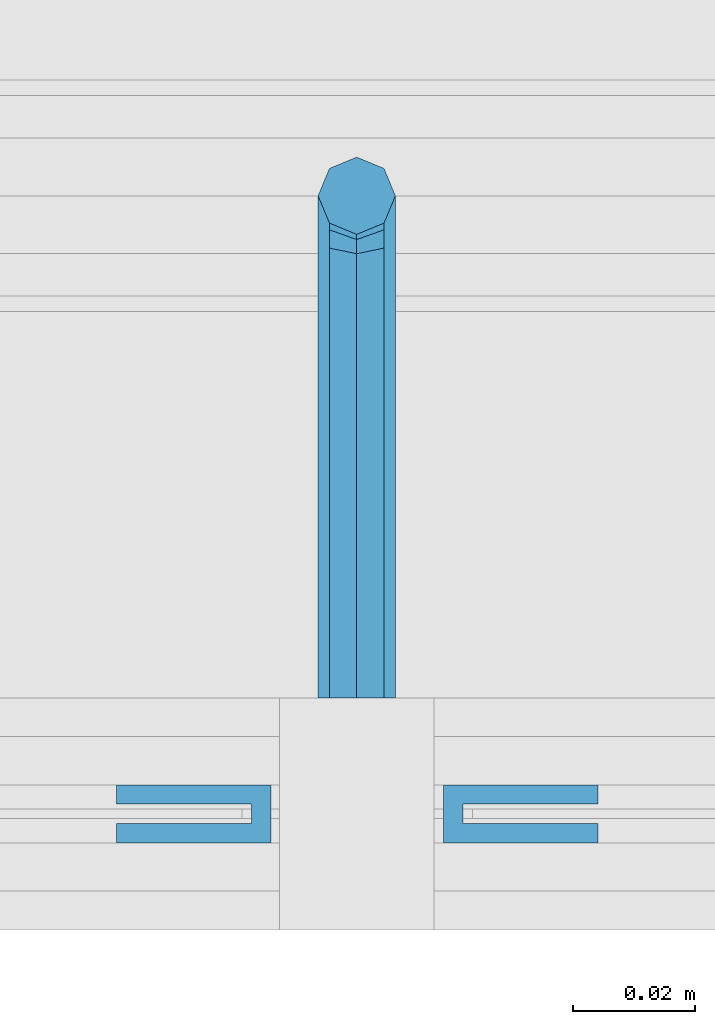
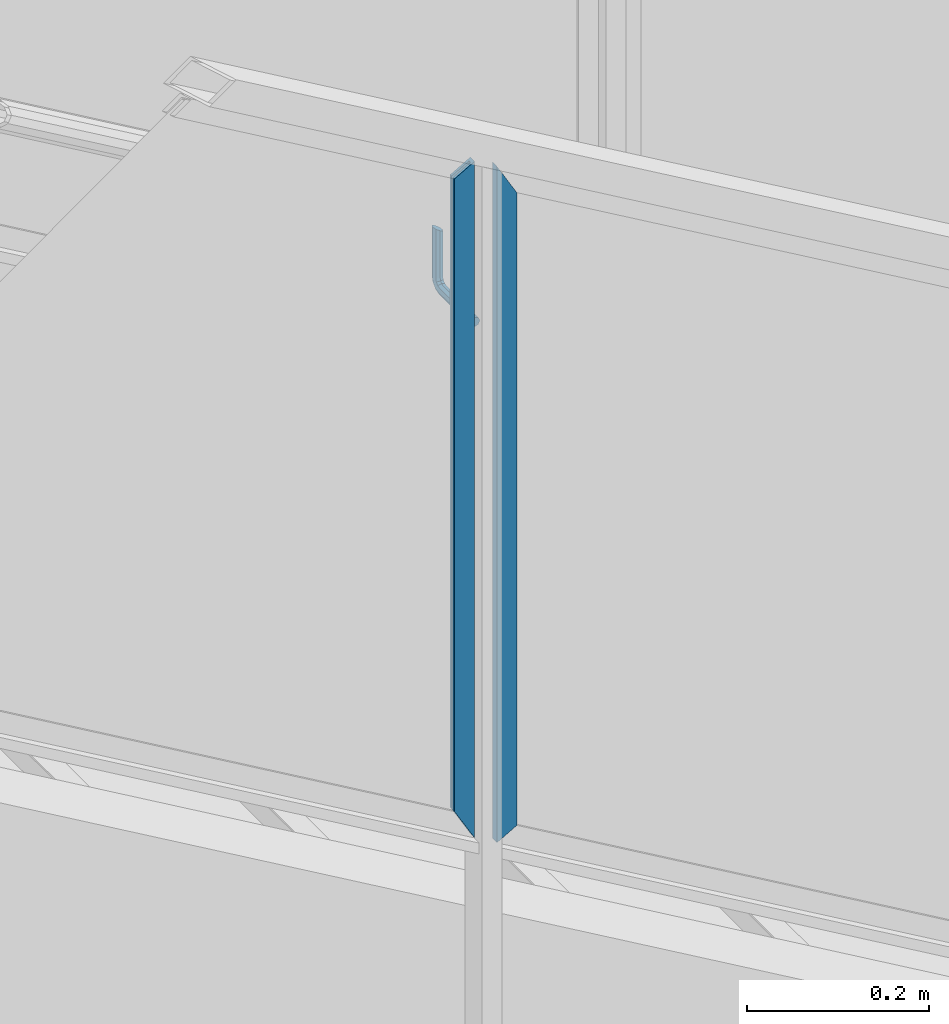
# One storey, part 938 of 1179: 3 beams, 1 element without a shape of its own.
"""IFC2X3 building model written with IfcOpenShell, lengths in millimetres."""

from ifc_helpers import new_model, si_unit, frame, origin_with_axes, place, context, subcontext, project, spatial, faceted_brep, material, type_object, element, aggregate, save


model = new_model("IFC2X3")

# Units and contexts
model_context = context("Model", 3, precision=1e-05, world=origin_with_axes())
body_context = subcontext(model_context, "Body", "Model", "MODEL_VIEW")
ifc_project = project(units=[si_unit("LENGTHUNIT", "METRE", prefix="MILLI"), si_unit("AREAUNIT", "SQUARE_METRE"), si_unit("VOLUMEUNIT", "CUBIC_METRE"), si_unit("MASSUNIT", "GRAM", prefix="KILO"), si_unit("TIMEUNIT", "SECOND"), si_unit("PLANEANGLEUNIT", "RADIAN"), si_unit("SOLIDANGLEUNIT", "STERADIAN"), si_unit("THERMODYNAMICTEMPERATUREUNIT", "DEGREE_CELSIUS"), si_unit("LUMINOUSINTENSITYUNIT", "LUMEN")], contexts=[model_context])

# Site, building, storey
site_placement = place(None, origin_with_axes())
site = spatial("IfcSite", under=ifc_project, at=site_placement, CompositionType="ELEMENT")
building_placement = place(site_placement, origin_with_axes())
building = spatial("IfcBuilding", under=site, at=building_placement, Name="Undefined", CompositionType="ELEMENT")
storey_placement = place(building_placement, origin_with_axes())
storey = spatial("IfcBuildingStorey", under=building, at=storey_placement, Name="Undefined", CompositionType="ELEMENT", Elevation=0.0)

# Assembly, beams
assembly_placement = place(storey_placement, origin_with_axes())
assembly = element("IfcElementAssembly", 1, at=assembly_placement, inside=storey, Name="GUARDRAIL", AssemblyPlace="NOTDEFINED", PredefinedType="RIGID_FRAME")
ifc_material_1 = material(Name="STEEL/BUY-OUT")
beam_type_1 = type_object("IfcBeamType", PredefinedType="NOTDEFINED")
beam_1_placement = place(assembly_placement, frame((20770.4985085874, 39677.9751661883, 8158.38901805033), z_axis=(0.0, 0.0, -1.0), x_axis=(1.0, 0.0, 0.0)))
beam_1 = element("IfcBeam", 2, at=beam_1_placement, type_object=beam_type_1, material=ifc_material_1, Name="U-EDGE", context=body_context, shape_type="Brep", body=[
    faceted_brep([(0.0, 1.58750000000146, 410.596656611626), (0.0, -1.58750000000146, 410.596656611626), (22.2250000000131, -1.58750000000146, 449.291208105723), (22.2250000000131, -4.76249999999709, 449.291208105723), (2.91038304567337e-11, -4.76249999999709, 410.596656611676), (2.91038304567337e-11, -7.9375, 410.596656611676), (25.400000000016, -7.9375, 454.819), (25.400000000016, 1.58750000000146, 454.819), (25.400000000016, -7.9375, -454.041889813999), (25.400000000016, 1.58750000000146, -454.041889813999), (0.0, 1.58750000000146, -439.452883390265), (0.0, -1.58750000000146, -439.452883390265), (22.2250000000131, -1.58750000000146, -452.218264011032), (22.2250000000131, -4.76249999999709, -452.218264011032), (2.91038304567337e-11, -4.76249999999709, -439.452883390281), (2.91038304567337e-11, -7.9375, -439.452883390281)], [[[0, 1, 2, 3, 4, 5, 6, 7]], [[7, 6, 8, 9]], [[0, 7, 9, 10]], [[1, 0, 10, 11]], [[2, 1, 11, 12]], [[3, 2, 12, 13]], [[4, 3, 13, 14]], [[5, 4, 14, 15]], [[6, 5, 15, 8]], [[14, 13, 12, 11, 10, 9, 8, 15]]]),
])
beam_2_placement = place(assembly_placement, frame((20849.6958338412, 39677.9751661883, 8141.04680149776), z_axis=(0.0, 0.0, -1.0), x_axis=(-1.0, 0.0, 0.0)))
beam_2 = element("IfcBeam", 3, at=beam_2_placement, type_object=beam_type_1, material=ifc_material_1, Name="U-EDGE", context=body_context, shape_type="Brep", body=[
    faceted_brep([(2.91038304567337e-11, 7.9375, 439.454484500298), (25.400000000016, 7.9375, 454.043488866833), (25.400000000016, 7.9375, -454.819), (2.91038304567337e-11, 7.9375, -410.596660287256), (2.91038304567337e-11, 4.76249999999709, 439.454484500298), (2.91038304567337e-11, 4.76249999999709, -410.596660287256), (22.2250000000131, 4.76249999999709, 452.219863321016), (22.2250000000131, 4.76249999999709, -449.290437478487), (22.2250000000131, 1.58750000000146, 452.219863321016), (22.2250000000131, 1.58750000000146, -449.290437478487), (0.0, 1.58750000000146, 439.454484500282), (0.0, 1.58750000000146, -410.596660287205), (0.0, -1.58750000000146, 439.454484500282), (0.0, -1.58750000000146, -410.596660287205), (25.400000000016, -1.58750000000146, 454.043488866833), (25.400000000016, -1.58750000000146, -454.819)], [[[0, 1, 2, 3]], [[4, 0, 3, 5]], [[6, 4, 5, 7]], [[8, 6, 7, 9]], [[10, 8, 9, 11]], [[12, 10, 11, 13]], [[14, 12, 13, 15]], [[11, 9, 7, 5, 3, 2, 15, 13]], [[1, 14, 15, 2]], [[0, 4, 6, 8, 10, 12, 14, 1]]]),
])
ifc_material_2 = material(Name="STEEL/A36")
beam_type_2 = type_object("IfcBeamType", PredefinedType="NOTDEFINED")
beam_3_placement = place(assembly_placement, frame((20810.0083338412, 39700.2000007796, 8377.32005614214), z_axis=(0.0, 0.0, 1.0), x_axis=(0.0, 1.0, 0.0)))
beam_3 = element("IfcBeam", 4, at=beam_3_placement, type_object=beam_type_2, material=ifc_material_2, Name="BRACKET", context=body_context, shape_type="Brep", body=[
    faceted_brep([(0.0, 0.0, 6.34999999999991), (0.0, -4.49012806053361, 4.49012806053452), (69.849999425729, -4.49012806053361, 4.49012806053452), (69.849999425729, 0.0, 6.34999999999991), (0.0, 4.49012806053361, 4.49012806053452), (69.849999425729, 4.49012806053361, 4.49012806053452), (0.0, 6.34999999999854, 0.0), (69.849999425729, 6.34999999999854, 0.0), (0.0, 4.49012806053361, -4.49012806053452), (69.849999425729, 4.49012806053361, -4.49012806053452), (0.0, 0.0, -6.34999999999991), (69.849999425729, 0.0, -6.34999999999991), (0.0, -4.49012806053361, -4.49012806053452), (69.849999425729, -4.49012806053361, -4.49012806053452), (0.0, -6.34999999999854, 0.0), (69.849999425729, -6.34999999999854, 0.0), (76.1999993303689, -6.34999999999854, 1.70147734638658), (73.9549353000984, -4.49012806053361, 5.59004231305425), (73.024999330366, 0.0, 7.20073866041639), (73.9549353000984, 4.49012806053361, 5.59004231305425), (76.1999993303689, 6.34999999999854, 1.70147734638658), (78.445063360632, 4.49012806053361, -2.18708762028064), (79.3749993303718, 0.0, -3.79778396764323), (78.445063360632, -4.49012806053361, -2.18708762028064), (84.7370868552753, 4.49012806053361, 4.10493587436031), (87.0401272955278, 4.49012806053361, 12.6999998092651), (88.8999992349927, 0.0, 12.6999998092651), (86.3477832026401, 0.0, 3.17499990462693), (80.8485218886053, 6.34999999999854, 6.34999990462893), (82.5499992349942, 6.34999999999854, 12.6999998092651), (76.9599569219426, 4.49012806053361, 8.59506393489755), (78.0598711744606, 4.49012806053361, 12.6999998092651), (75.3492605745778, 0.0, 9.52499990463093), (76.1999992349956, 0.0, 12.6999998092651), (76.9599569219426, -4.49012806053361, 8.59506393489755), (78.0598711744606, -4.49012806053361, 12.6999998092651), (80.8485218886053, -6.34999999999854, 6.34999990462893), (82.5499992349942, -6.34999999999854, 12.6999998092651), (84.7370868552753, -4.49012806053361, 4.10493587436031), (87.0401272955278, -4.49012806053361, 12.6999998092651), (88.8999992349927, 0.0, 76.2000000000003), (87.0401272955278, -4.49012806053361, 73.5797637174637), (82.5499992349942, -6.34999999999854, 72.4944263126154), (78.0598711744606, -4.49012806053361, 73.5797637174637), (76.1999992349956, 0.0, 76.2000000000003), (78.0598711744606, 4.49012806053361, 78.8202362825368), (82.5499992349942, 6.34999999999854, 79.8943188022276), (87.0401272955278, 4.49012806053361, 78.8202362825368)], [[[0, 1, 2, 3]], [[4, 0, 3, 5]], [[6, 4, 5, 7]], [[8, 6, 7, 9]], [[10, 8, 9, 11]], [[12, 10, 11, 13]], [[1, 0, 4, 6, 8, 10, 12, 14]], [[1, 14, 15, 2]], [[14, 12, 13, 15]], [[2, 15, 16, 17]], [[3, 2, 17, 18]], [[5, 3, 18, 19]], [[7, 5, 19, 20]], [[9, 7, 20, 21]], [[11, 9, 21, 22]], [[13, 11, 22, 23]], [[24, 25, 26, 27]], [[28, 29, 25, 24]], [[30, 31, 29, 28]], [[32, 33, 31, 30]], [[34, 35, 33, 32]], [[36, 37, 35, 34]], [[38, 39, 37, 36]], [[27, 26, 39, 38]], [[22, 27, 38, 23]], [[21, 24, 27, 22]], [[20, 28, 24, 21]], [[19, 30, 28, 20]], [[18, 32, 30, 19]], [[17, 34, 32, 18]], [[16, 36, 34, 17]], [[23, 38, 36, 16]], [[15, 13, 23, 16]], [[39, 26, 40, 41]], [[37, 39, 41, 42]], [[35, 37, 42, 43]], [[33, 35, 43, 44]], [[31, 33, 44, 45]], [[29, 31, 45, 46]], [[25, 29, 46, 47]], [[26, 25, 47, 40]], [[46, 45, 44, 43, 42, 41, 40, 47]]]),
])
aggregate(assembly, [beam_3, beam_1, beam_2])

save(model, "model.ifc")
